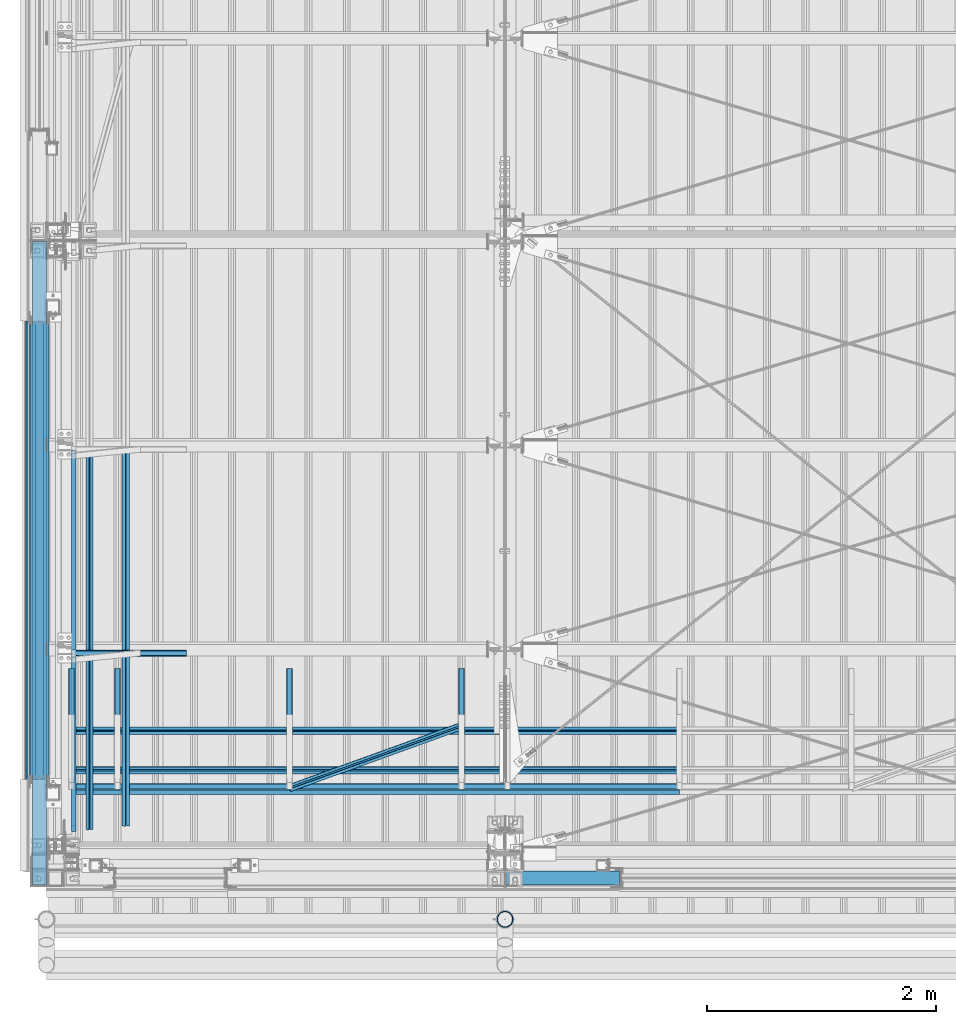
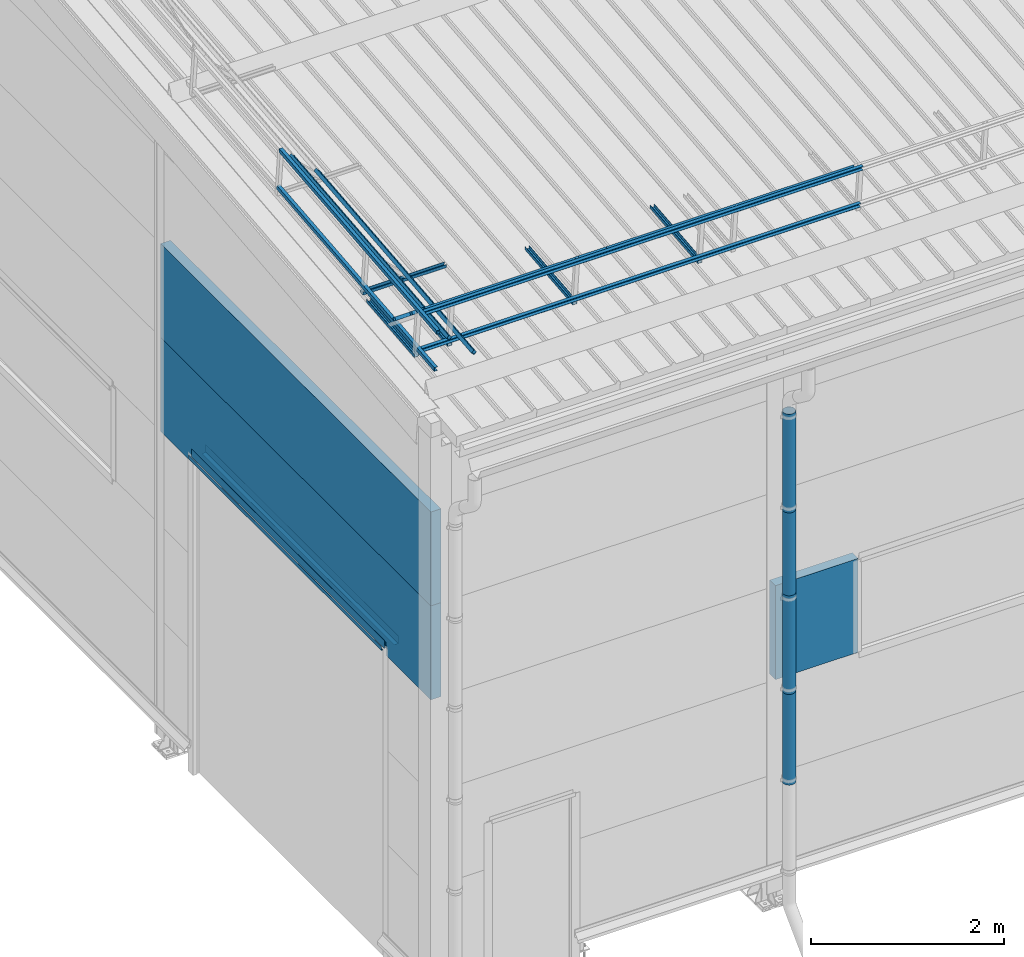
# One storey, part 29 of 709: 25 beams, 1 opening, 25 elements without a shape of their own.
"""IFC4 building model written with IfcOpenShell, lengths in millimetres."""

from ifc_helpers import new_model, si_unit, direction, frame, origin_with_axes, place, context, subcontext, project, spatial, line, indexed_curve, outline, extrude, material, element, aggregate, save


model = new_model("IFC4")

# Units and contexts
model_context = context("Model", 3, precision=0.2, world=origin_with_axes(), true_north=direction((0.0, 1.0)))
body_context = subcontext(model_context, "Body", "Model", "MODEL_VIEW")
ifc_project = project(units=[si_unit("LENGTHUNIT", "METRE", prefix="MILLI"), si_unit("AREAUNIT", "SQUARE_METRE"), si_unit("VOLUMEUNIT", "CUBIC_METRE"), si_unit("MASSUNIT", "GRAM", prefix="KILO"), si_unit("TIMEUNIT", "SECOND"), si_unit("PLANEANGLEUNIT", "RADIAN"), si_unit("SOLIDANGLEUNIT", "STERADIAN"), si_unit("THERMODYNAMICTEMPERATUREUNIT", "DEGREE_CELSIUS"), si_unit("LUMINOUSINTENSITYUNIT", "LUMEN")], contexts=[model_context])

# Site, building, storey
site_placement = place(None, origin_with_axes())
site = spatial("IfcSite", under=ifc_project, at=site_placement, CompositionType="ELEMENT")
building_placement = place(site_placement, origin_with_axes())
building = spatial("IfcBuilding", under=site, at=building_placement, Name="Undefined", CompositionType="ELEMENT")
storey_placement = place(building_placement, origin_with_axes())
storey = spatial("IfcBuildingStorey", under=building, at=storey_placement, Name="Undefined", CompositionType="ELEMENT", Elevation=0.0)

# Assembly, beam
assembly_1_placement = place(storey_placement, frame((220.0, 768.92298, 7577.16191), z_axis=(0.0, -0.099503719, 0.9950371902), x_axis=(0.0, 0.9950371902, 0.099503719)))
assembly_1 = element("IfcElementAssembly", 1, at=assembly_1_placement, inside=storey)
ifc_material_1 = material(Name="Steel_Undefined", Category="STEEL")
beam_1_placement = place(assembly_1_placement, origin_with_axes())
beam_1 = element("IfcBeam", 2, at=beam_1_placement, material=ifc_material_1, ObjectType="601", context=body_context, shape_type="SolidModel", body=[
    extrude(outline(indexed_curve([(-20.0, -25.0), (20.0, -25.0), (20.0, -22.5), (-17.5, -22.5), (-17.5, 22.5), (20.0, 22.5), (20.0, 25.0), (-20.0, 25.0)], segments=[line(1, 2, 3, 4, 5, 6, 7, 8, 1)])), frame((0.0, 0.0, 0.0), z_axis=(-1.0, 0.0, 0.0), x_axis=(0.0, 0.0, 1.0)), (0.0, 0.0, -1.0), 1000.0),
])
aggregate(assembly_1, [beam_1])

assembly_2_placement = place(storey_placement, frame((620.0, 768.92298, 7577.16191), z_axis=(0.0, -0.099503719, 0.9950371902), x_axis=(0.0, 0.9950371902, 0.099503719)))
assembly_2 = element("IfcElementAssembly", 3, at=assembly_2_placement, inside=storey)
beam_2_placement = place(assembly_2_placement, origin_with_axes())
beam_2 = element("IfcBeam", 4, at=beam_2_placement, material=ifc_material_1, ObjectType="601", context=body_context, shape_type="SolidModel", body=[
    extrude(outline(indexed_curve([(-20.0, -25.0), (20.0, -25.0), (20.0, -22.5), (-17.5, -22.5), (-17.5, 22.5), (20.0, 22.5), (20.0, 25.0), (-20.0, 25.0)], segments=[line(1, 2, 3, 4, 5, 6, 7, 8, 1)])), frame((0.0, 0.0, 0.0), z_axis=(-1.0, 0.0, 0.0), x_axis=(0.0, 0.0, 1.0)), (0.0, 0.0, -1.0), 1000.0),
])
aggregate(assembly_2, [beam_2])

assembly_3_placement = place(storey_placement, frame((2120.0, 768.92298, 7577.16191), z_axis=(0.0, -0.099503719, 0.9950371902), x_axis=(0.0, 0.9950371902, 0.099503719)))
assembly_3 = element("IfcElementAssembly", 5, at=assembly_3_placement, inside=storey)
beam_3_placement = place(assembly_3_placement, origin_with_axes())
beam_3 = element("IfcBeam", 6, at=beam_3_placement, material=ifc_material_1, ObjectType="601", context=body_context, shape_type="SolidModel", body=[
    extrude(outline(indexed_curve([(-20.0, -25.0), (20.0, -25.0), (20.0, -22.5), (-17.5, -22.5), (-17.5, 22.5), (20.0, 22.5), (20.0, 25.0), (-20.0, 25.0)], segments=[line(1, 2, 3, 4, 5, 6, 7, 8, 1)])), frame((0.0, 0.0, 0.0), z_axis=(-1.0, 0.0, 0.0), x_axis=(0.0, 0.0, 1.0)), (0.0, 0.0, -1.0), 1000.0),
])
aggregate(assembly_3, [beam_3])

assembly_4_placement = place(storey_placement, frame((3620.0, 768.92298, 7577.16191), z_axis=(0.0, -0.099503719, 0.9950371902), x_axis=(0.0, 0.9950371902, 0.099503719)))
assembly_4 = element("IfcElementAssembly", 7, at=assembly_4_placement, inside=storey)
beam_4_placement = place(assembly_4_placement, origin_with_axes())
beam_4 = element("IfcBeam", 8, at=beam_4_placement, material=ifc_material_1, ObjectType="601", context=body_context, shape_type="SolidModel", body=[
    extrude(outline(indexed_curve([(-20.0, -25.0), (20.0, -25.0), (20.0, -22.5), (-17.5, -22.5), (-17.5, 22.5), (20.0, 22.5), (20.0, 25.0), (-20.0, 25.0)], segments=[line(1, 2, 3, 4, 5, 6, 7, 8, 1)])), frame((0.0, 0.0, 0.0), z_axis=(-1.0, 0.0, 0.0), x_axis=(0.0, 0.0, 1.0)), (0.0, 0.0, -1.0), 1000.0),
])
aggregate(assembly_4, [beam_4])

assembly_5_placement = place(storey_placement, frame((220.0, 691.31008, 8152.29341), z_axis=(0.0, -0.9950371902, -0.099503719), x_axis=(1.0, 0.0, 0.0)))
assembly_5 = element("IfcElementAssembly", 9, at=assembly_5_placement, inside=storey)
beam_5_placement = place(assembly_5_placement, origin_with_axes())
beam_5 = element("IfcBeam", 10, at=beam_5_placement, material=ifc_material_1, ObjectType="604", context=body_context, shape_type="SolidModel", body=[
    extrude(outline(indexed_curve([(-20.0, -25.0), (20.0, -25.0), (20.0, -22.5), (-17.5, -22.5), (-17.5, 22.5), (20.0, 22.5), (20.0, 25.0), (-20.0, 25.0)], segments=[line(1, 2, 3, 4, 5, 6, 7, 8, 1)])), frame((0.0, 0.0, 0.0), z_axis=(-1.0, 0.0, 0.0), x_axis=(0.0, 0.0, 1.0)), (0.0, 0.0, -1.0), 5300.0),
])
aggregate(assembly_5, [beam_5])

assembly_6_placement = place(storey_placement, frame((220.0, 741.06194, 7654.77481), z_axis=(0.0, -0.9950371902, -0.099503719), x_axis=(1.0, 0.0, 0.0)))
assembly_6 = element("IfcElementAssembly", 11, at=assembly_6_placement, inside=storey)
beam_6_placement = place(assembly_6_placement, origin_with_axes())
beam_6 = element("IfcBeam", 12, at=beam_6_placement, material=ifc_material_1, ObjectType="604", context=body_context, shape_type="SolidModel", body=[
    extrude(outline(indexed_curve([(-20.0, -25.0), (20.0, -25.0), (20.0, -22.5), (-17.5, -22.5), (-17.5, 22.5), (20.0, 22.5), (20.0, 25.0), (-20.0, 25.0)], segments=[line(1, 2, 3, 4, 5, 6, 7, 8, 1)])), frame((0.0, 0.0, 0.0), z_axis=(-1.0, 0.0, 0.0), x_axis=(0.0, 0.0, 1.0)), (0.0, 0.0, -1.0), 5300.0),
])
aggregate(assembly_6, [beam_6])

assembly_7_placement = place(storey_placement, frame((220.0, 878.66704, 8043.11507), z_axis=(0.0, 0.6332377902, 0.7739572992), x_axis=(1.0, 0.0, 0.0)))
assembly_7 = element("IfcElementAssembly", 13, at=assembly_7_placement, inside=storey)
beam_7_placement = place(assembly_7_placement, origin_with_axes())
beam_7 = element("IfcBeam", 14, at=beam_7_placement, material=ifc_material_1, ObjectType="604", context=body_context, shape_type="SolidModel", body=[
    extrude(outline(indexed_curve([(-20.0, -25.0), (20.0, -25.0), (20.0, -22.5), (-17.5, -22.5), (-17.5, 22.5), (20.0, 22.5), (20.0, 25.0), (-20.0, 25.0)], segments=[line(1, 2, 3, 4, 5, 6, 7, 8, 1)])), frame((0.0, 0.0, 0.0), z_axis=(-1.0, 0.0, 0.0), x_axis=(0.0, 0.0, 1.0)), (0.0, 0.0, -1.0), 5300.0),
])
aggregate(assembly_7, [beam_7])

assembly_8_placement = place(storey_placement, frame((220.0, 1225.80867, 7759.0901), z_axis=(0.0, 0.6332377902, 0.7739572992), x_axis=(1.0, 0.0, 0.0)))
assembly_8 = element("IfcElementAssembly", 15, at=assembly_8_placement, inside=storey)
beam_8_placement = place(assembly_8_placement, origin_with_axes())
beam_8 = element("IfcBeam", 16, at=beam_8_placement, material=ifc_material_1, ObjectType="604", context=body_context, shape_type="SolidModel", body=[
    extrude(outline(indexed_curve([(-20.0, -25.0), (20.0, -25.0), (20.0, -22.5), (-17.5, -22.5), (-17.5, 22.5), (20.0, 22.5), (20.0, 25.0), (-20.0, 25.0)], segments=[line(1, 2, 3, 4, 5, 6, 7, 8, 1)])), frame((0.0, 0.0, 0.0), z_axis=(-1.0, 0.0, 0.0), x_axis=(0.0, 0.0, 1.0)), (0.0, 0.0, -1.0), 5300.0),
])
aggregate(assembly_8, [beam_8])

assembly_9_placement = place(storey_placement, frame((2120.0, 723.87558, 8169.76263), z_axis=(0.0, 0.6332377902, 0.7739572992), x_axis=(0.9061831398, 0.3272952929, -0.2677870579)))
assembly_9 = element("IfcElementAssembly", 17, at=assembly_9_placement, inside=storey)
beam_9_placement = place(assembly_9_placement, origin_with_axes())
beam_9 = element("IfcBeam", 18, at=beam_9_placement, material=ifc_material_1, ObjectType="605", context=body_context, shape_type="SolidModel", body=[
    extrude(outline(indexed_curve([(-20.0, -25.0), (20.0, -25.0), (20.0, -22.5), (-17.5, -22.5), (-17.5, 22.5), (20.0, 22.5), (20.0, 25.0), (-20.0, 25.0)], segments=[line(1, 2, 3, 4, 5, 6, 7, 8, 1)])), frame((0.0, 0.0, 0.0), z_axis=(-1.0, 0.0, 0.0), x_axis=(0.0, 0.0, 1.0)), (0.0, 0.0, -1.0), 1655.29454),
])
aggregate(assembly_9, [beam_9])

assembly_10_placement = place(storey_placement, frame((220.0, 1899.83375, 7690.25299), z_axis=(0.0, -0.099503719, 0.9950371902), x_axis=(1.0, 0.0, 0.0)))
assembly_10 = element("IfcElementAssembly", 19, at=assembly_10_placement, inside=storey)
beam_10_placement = place(assembly_10_placement, origin_with_axes())
beam_10 = element("IfcBeam", 20, at=beam_10_placement, material=ifc_material_1, ObjectType="601", context=body_context, shape_type="SolidModel", body=[
    extrude(outline(indexed_curve([(-20.0, -25.0), (20.0, -25.0), (20.0, -22.5), (-17.5, -22.5), (-17.5, 22.5), (20.0, 22.5), (20.0, 25.0), (-20.0, 25.0)], segments=[line(1, 2, 3, 4, 5, 6, 7, 8, 1)])), frame((0.0, 0.0, 0.0), z_axis=(-1.0, 0.0, 0.0), x_axis=(0.0, 0.0, 1.0)), (0.0, 0.0, -1.0), 1000.0),
])
aggregate(assembly_10, [beam_10])

assembly_11_placement = place(storey_placement, frame((240.0, 349.56581, 8118.11898), z_axis=(1.0, 0.0, 0.0), x_axis=(0.0, 0.9950371902, 0.099503719)))
assembly_11 = element("IfcElementAssembly", 21, at=assembly_11_placement, inside=storey)
beam_11_placement = place(assembly_11_placement, origin_with_axes())
beam_11 = element("IfcBeam", 22, at=beam_11_placement, material=ifc_material_1, ObjectType="608", context=body_context, shape_type="SolidModel", body=[
    extrude(outline(indexed_curve([(-20.0, -25.0), (20.0, -25.0), (20.0, -22.5), (-17.5, -22.5), (-17.5, 22.5), (20.0, 22.5), (20.0, 25.0), (-20.0, 25.0)], segments=[line(1, 2, 3, 4, 5, 6, 7, 8, 1)])), frame((0.0, 0.0, 0.0), z_axis=(-1.0, 0.0, 0.0), x_axis=(0.0, 0.0, 1.0)), (0.0, 0.0, -1.0), 3285.56115),
])
aggregate(assembly_11, [beam_11])

assembly_12_placement = place(storey_placement, frame((240.0, 399.31767, 7620.60038), z_axis=(1.0, 0.0, 0.0), x_axis=(0.0, 0.9950371902, 0.099503719)))
assembly_12 = element("IfcElementAssembly", 23, at=assembly_12_placement, inside=storey)
beam_12_placement = place(assembly_12_placement, origin_with_axes())
beam_12 = element("IfcBeam", 24, at=beam_12_placement, material=ifc_material_1, ObjectType="608", context=body_context, shape_type="SolidModel", body=[
    extrude(outline(indexed_curve([(-20.0, -25.0), (20.0, -25.0), (20.0, -22.5), (-17.5, -22.5), (-17.5, 22.5), (20.0, 22.5), (20.0, 25.0), (-20.0, 25.0)], segments=[line(1, 2, 3, 4, 5, 6, 7, 8, 1)])), frame((0.0, 0.0, 0.0), z_axis=(-1.0, 0.0, 0.0), x_axis=(0.0, 0.0, 1.0)), (0.0, 0.0, -1.0), 3285.56115),
])
aggregate(assembly_12, [beam_12])

assembly_13_placement = place(storey_placement, frame((375.56349, 362.23056, 7991.47142), z_axis=(0.7071067814, -0.0703597545, 0.7035975445), x_axis=(0.0, 0.9950371902, 0.099503719)))
assembly_13 = element("IfcElementAssembly", 25, at=assembly_13_placement, inside=storey)
beam_13_placement = place(assembly_13_placement, origin_with_axes())
beam_13 = element("IfcBeam", 26, at=beam_13_placement, material=ifc_material_1, ObjectType="608", context=body_context, shape_type="SolidModel", body=[
    extrude(outline(indexed_curve([(-20.0, -25.0), (20.0, -25.0), (20.0, -22.5), (-17.5, -22.5), (-17.5, 22.5), (20.0, 22.5), (20.0, 25.0), (-20.0, 25.0)], segments=[line(1, 2, 3, 4, 5, 6, 7, 8, 1)])), frame((0.0, 0.0, 0.0), z_axis=(-1.0, 0.0, 0.0), x_axis=(0.0, 0.0, 1.0)), (0.0, 0.0, -1.0), 3285.56115),
])
aggregate(assembly_13, [beam_13])

assembly_14_placement = place(storey_placement, frame((692.72078, 393.78889, 7675.88813), z_axis=(0.7071067814, -0.0703597545, 0.7035975445), x_axis=(0.0, 0.9950371902, 0.099503719)))
assembly_14 = element("IfcElementAssembly", 27, at=assembly_14_placement, inside=storey)
beam_14_placement = place(assembly_14_placement, origin_with_axes())
beam_14 = element("IfcBeam", 28, at=beam_14_placement, material=ifc_material_1, ObjectType="608", context=body_context, shape_type="SolidModel", body=[
    extrude(outline(indexed_curve([(-20.0, -25.0), (20.0, -25.0), (20.0, -22.5), (-17.5, -22.5), (-17.5, 22.5), (20.0, 22.5), (20.0, 25.0), (-20.0, 25.0)], segments=[line(1, 2, 3, 4, 5, 6, 7, 8, 1)])), frame((0.0, 0.0, 0.0), z_axis=(-1.0, 0.0, 0.0), x_axis=(0.0, 0.0, 1.0)), (0.0, 0.0, -1.0), 3285.56115),
])
aggregate(assembly_14, [beam_14])

assembly_15_placement = place(storey_placement, frame((4010.0, -60.0, 3275.0), z_axis=(0.0, 0.0, -1.0), x_axis=(1.0, 0.0, 0.0)))
assembly_15 = element("IfcElementAssembly", 29, at=assembly_15_placement, inside=storey)
ifc_material_2 = material(Name="Insulation", Category="Insulation")
beam_15_placement = place(assembly_15_placement, origin_with_axes())
beam_15 = element("IfcBeam", 30, at=beam_15_placement, material=ifc_material_2, ObjectType="P-110", context=body_context, shape_type="SolidModel", body=[
    extrude(outline(indexed_curve([(-595.0, -60.0), (595.0, -60.0), (595.0, 60.0), (-595.0, 60.0)], segments=[line(1, 2, 3, 4, 1)])), frame((0.0, 0.0, 0.0), z_axis=(-1.0, 0.0, 0.0), x_axis=(0.0, 0.0, 1.0)), (0.0, 0.0, -1.0), 990.0),
])
aggregate(assembly_15, [beam_15])

assembly_16_placement = place(storey_placement, frame((4000.0, -420.0, 6276.92297), z_axis=(0.0, 1.0, 0.0), x_axis=(0.0, 0.0, -1.0)))
assembly_16 = element("IfcElementAssembly", 31, at=assembly_16_placement, inside=storey)
beam_16_placement = place(assembly_16_placement, origin_with_axes())
beam_16 = element("IfcBeam", 32, at=beam_16_placement, material=ifc_material_1, ObjectType="614", context=body_context, shape_type="SolidModel", body=[
    extrude(outline(indexed_curve([(70.0, 0.0), (69.61653, 7.31699), (68.47033, 14.55382), (66.57396, 21.63119), (63.94818, 28.47157), (60.62178, 35.0), (56.63119, 41.14497), (52.02014, 46.83914), (46.83914, 52.02014), (41.14497, 56.63119), (35.0, 60.62178), (28.47157, 63.94818), (21.63119, 66.57396), (14.55382, 68.47033), (7.31699, 69.61653), (0.0, 70.0), (-7.31699, 69.61653), (-14.55382, 68.47033), (-21.63119, 66.57396), (-28.47157, 63.94818), (-35.0, 60.62178), (-41.14497, 56.63119), (-46.83914, 52.02014), (-52.02014, 46.83914), (-56.63119, 41.14497), (-60.62178, 35.0), (-63.94818, 28.47157), (-66.57396, 21.63119), (-68.47033, 14.55382), (-69.61653, 7.31699), (-70.0, 0.0), (-69.61653, -7.31699), (-68.47033, -14.55382), (-66.57396, -21.63119), (-63.94818, -28.47157), (-60.62178, -35.0), (-56.63119, -41.14497), (-52.02014, -46.83914), (-46.83914, -52.02014), (-41.14497, -56.63119), (-35.0, -60.62178), (-28.47157, -63.94818), (-21.63119, -66.57396), (-14.55382, -68.47033), (-7.31699, -69.61653), (0.0, -70.0), (7.31699, -69.61653), (14.55382, -68.47033), (21.63119, -66.57396), (28.47157, -63.94818), (35.0, -60.62178), (41.14497, -56.63119), (46.83914, -52.02014), (52.02014, -46.83914), (56.63119, -41.14497), (60.62178, -35.0), (63.94818, -28.47157), (66.57396, -21.63119), (68.47033, -14.55382), (69.61653, -7.31699)], segments=[line(1, 2, 3, 4, 5, 6, 7, 8, 9, 10, 11, 12, 13, 14, 15, 16, 17, 18, 19, 20, 21, 22, 23, 24, 25, 26, 27, 28, 29, 30, 31, 32, 33, 34, 35, 36, 37, 38, 39, 40, 41, 42, 43, 44, 45, 46, 47, 48, 49, 50, 51, 52, 53, 54, 55, 56, 57, 58, 59, 60, 1)]), holes=[indexed_curve([(65.0, 0.0), (64.64392, -6.79435), (63.57959, -13.51426), (61.81867, -20.0861), (59.38045, -26.43788), (56.29165, -32.5), (52.5861, -38.20604), (48.30441, -43.49349), (43.49349, -48.30441), (38.20604, -52.5861), (32.5, -56.29165), (26.43788, -59.38045), (20.0861, -61.81867), (13.51426, -63.57959), (6.79435, -64.64392), (0.0, -65.0), (-6.79435, -64.64392), (-13.51426, -63.57959), (-20.0861, -61.81867), (-26.43788, -59.38045), (-32.5, -56.29165), (-38.20604, -52.5861), (-43.49349, -48.30441), (-48.30441, -43.49349), (-52.5861, -38.20604), (-56.29165, -32.5), (-59.38045, -26.43788), (-61.81867, -20.0861), (-63.57959, -13.51426), (-64.64392, -6.79435), (-65.0, 0.0), (-64.64392, 6.79435), (-63.57959, 13.51426), (-61.81867, 20.0861), (-59.38045, 26.43788), (-56.29165, 32.5), (-52.5861, 38.20604), (-48.30441, 43.49349), (-43.49349, 48.30441), (-38.20604, 52.5861), (-32.5, 56.29165), (-26.43788, 59.38045), (-20.0861, 61.81867), (-13.51426, 63.57959), (-6.79435, 64.64392), (0.0, 65.0), (6.79435, 64.64392), (13.51426, 63.57959), (20.0861, 61.81867), (26.43788, 59.38045), (32.5, 56.29165), (38.20604, 52.5861), (43.49349, 48.30441), (48.30441, 43.49349), (52.5861, 38.20604), (56.29165, 32.5), (59.38045, 26.43788), (61.81867, 20.0861), (63.57959, 13.51426), (64.64392, 6.79435)], segments=[line(1, 2, 3, 4, 5, 6, 7, 8, 9, 10, 11, 12, 13, 14, 15, 16, 17, 18, 19, 20, 21, 22, 23, 24, 25, 26, 27, 28, 29, 30, 31, 32, 33, 34, 35, 36, 37, 38, 39, 40, 41, 42, 43, 44, 45, 46, 47, 48, 49, 50, 51, 52, 53, 54, 55, 56, 57, 58, 59, 60, 1)])]), frame((0.0, 0.0, 0.0), z_axis=(-1.0, 0.0, 0.0), x_axis=(0.0, 0.0, 1.0)), (0.0, 0.0, -1.0), 1250.0),
])
aggregate(assembly_16, [beam_16])

assembly_17_placement = place(storey_placement, frame((4000.0, -420.0, 5126.92297), z_axis=(0.0, 1.0, 0.0), x_axis=(0.0, 0.0, -1.0)))
assembly_17 = element("IfcElementAssembly", 33, at=assembly_17_placement, inside=storey)
beam_17_placement = place(assembly_17_placement, origin_with_axes())
beam_17 = element("IfcBeam", 34, at=beam_17_placement, material=ifc_material_1, ObjectType="614", context=body_context, shape_type="SolidModel", body=[
    extrude(outline(indexed_curve([(70.0, 0.0), (69.61653, 7.31699), (68.47033, 14.55382), (66.57396, 21.63119), (63.94818, 28.47157), (60.62178, 35.0), (56.63119, 41.14497), (52.02014, 46.83914), (46.83914, 52.02014), (41.14497, 56.63119), (35.0, 60.62178), (28.47157, 63.94818), (21.63119, 66.57396), (14.55382, 68.47033), (7.31699, 69.61653), (0.0, 70.0), (-7.31699, 69.61653), (-14.55382, 68.47033), (-21.63119, 66.57396), (-28.47157, 63.94818), (-35.0, 60.62178), (-41.14497, 56.63119), (-46.83914, 52.02014), (-52.02014, 46.83914), (-56.63119, 41.14497), (-60.62178, 35.0), (-63.94818, 28.47157), (-66.57396, 21.63119), (-68.47033, 14.55382), (-69.61653, 7.31699), (-70.0, 0.0), (-69.61653, -7.31699), (-68.47033, -14.55382), (-66.57396, -21.63119), (-63.94818, -28.47157), (-60.62178, -35.0), (-56.63119, -41.14497), (-52.02014, -46.83914), (-46.83914, -52.02014), (-41.14497, -56.63119), (-35.0, -60.62178), (-28.47157, -63.94818), (-21.63119, -66.57396), (-14.55382, -68.47033), (-7.31699, -69.61653), (0.0, -70.0), (7.31699, -69.61653), (14.55382, -68.47033), (21.63119, -66.57396), (28.47157, -63.94818), (35.0, -60.62178), (41.14497, -56.63119), (46.83914, -52.02014), (52.02014, -46.83914), (56.63119, -41.14497), (60.62178, -35.0), (63.94818, -28.47157), (66.57396, -21.63119), (68.47033, -14.55382), (69.61653, -7.31699)], segments=[line(1, 2, 3, 4, 5, 6, 7, 8, 9, 10, 11, 12, 13, 14, 15, 16, 17, 18, 19, 20, 21, 22, 23, 24, 25, 26, 27, 28, 29, 30, 31, 32, 33, 34, 35, 36, 37, 38, 39, 40, 41, 42, 43, 44, 45, 46, 47, 48, 49, 50, 51, 52, 53, 54, 55, 56, 57, 58, 59, 60, 1)]), holes=[indexed_curve([(65.0, 0.0), (64.64392, -6.79435), (63.57959, -13.51426), (61.81867, -20.0861), (59.38045, -26.43788), (56.29165, -32.5), (52.5861, -38.20604), (48.30441, -43.49349), (43.49349, -48.30441), (38.20604, -52.5861), (32.5, -56.29165), (26.43788, -59.38045), (20.0861, -61.81867), (13.51426, -63.57959), (6.79435, -64.64392), (0.0, -65.0), (-6.79435, -64.64392), (-13.51426, -63.57959), (-20.0861, -61.81867), (-26.43788, -59.38045), (-32.5, -56.29165), (-38.20604, -52.5861), (-43.49349, -48.30441), (-48.30441, -43.49349), (-52.5861, -38.20604), (-56.29165, -32.5), (-59.38045, -26.43788), (-61.81867, -20.0861), (-63.57959, -13.51426), (-64.64392, -6.79435), (-65.0, 0.0), (-64.64392, 6.79435), (-63.57959, 13.51426), (-61.81867, 20.0861), (-59.38045, 26.43788), (-56.29165, 32.5), (-52.5861, 38.20604), (-48.30441, 43.49349), (-43.49349, 48.30441), (-38.20604, 52.5861), (-32.5, 56.29165), (-26.43788, 59.38045), (-20.0861, 61.81867), (-13.51426, 63.57959), (-6.79435, 64.64392), (0.0, 65.0), (6.79435, 64.64392), (13.51426, 63.57959), (20.0861, 61.81867), (26.43788, 59.38045), (32.5, 56.29165), (38.20604, 52.5861), (43.49349, 48.30441), (48.30441, 43.49349), (52.5861, 38.20604), (56.29165, 32.5), (59.38045, 26.43788), (61.81867, 20.0861), (63.57959, 13.51426), (64.64392, 6.79435)], segments=[line(1, 2, 3, 4, 5, 6, 7, 8, 9, 10, 11, 12, 13, 14, 15, 16, 17, 18, 19, 20, 21, 22, 23, 24, 25, 26, 27, 28, 29, 30, 31, 32, 33, 34, 35, 36, 37, 38, 39, 40, 41, 42, 43, 44, 45, 46, 47, 48, 49, 50, 51, 52, 53, 54, 55, 56, 57, 58, 59, 60, 1)])]), frame((0.0, 0.0, 0.0), z_axis=(-1.0, 0.0, 0.0), x_axis=(0.0, 0.0, 1.0)), (0.0, 0.0, -1.0), 1250.0),
])
aggregate(assembly_17, [beam_17])

assembly_18_placement = place(storey_placement, frame((4000.0, -420.0, 3976.92297), z_axis=(0.0, 1.0, 0.0), x_axis=(0.0, 0.0, -1.0)))
assembly_18 = element("IfcElementAssembly", 35, at=assembly_18_placement, inside=storey)
beam_18_placement = place(assembly_18_placement, origin_with_axes())
beam_18 = element("IfcBeam", 36, at=beam_18_placement, material=ifc_material_1, ObjectType="614", context=body_context, shape_type="SolidModel", body=[
    extrude(outline(indexed_curve([(70.0, 0.0), (69.61653, 7.31699), (68.47033, 14.55382), (66.57396, 21.63119), (63.94818, 28.47157), (60.62178, 35.0), (56.63119, 41.14497), (52.02014, 46.83914), (46.83914, 52.02014), (41.14497, 56.63119), (35.0, 60.62178), (28.47157, 63.94818), (21.63119, 66.57396), (14.55382, 68.47033), (7.31699, 69.61653), (0.0, 70.0), (-7.31699, 69.61653), (-14.55382, 68.47033), (-21.63119, 66.57396), (-28.47157, 63.94818), (-35.0, 60.62178), (-41.14497, 56.63119), (-46.83914, 52.02014), (-52.02014, 46.83914), (-56.63119, 41.14497), (-60.62178, 35.0), (-63.94818, 28.47157), (-66.57396, 21.63119), (-68.47033, 14.55382), (-69.61653, 7.31699), (-70.0, 0.0), (-69.61653, -7.31699), (-68.47033, -14.55382), (-66.57396, -21.63119), (-63.94818, -28.47157), (-60.62178, -35.0), (-56.63119, -41.14497), (-52.02014, -46.83914), (-46.83914, -52.02014), (-41.14497, -56.63119), (-35.0, -60.62178), (-28.47157, -63.94818), (-21.63119, -66.57396), (-14.55382, -68.47033), (-7.31699, -69.61653), (0.0, -70.0), (7.31699, -69.61653), (14.55382, -68.47033), (21.63119, -66.57396), (28.47157, -63.94818), (35.0, -60.62178), (41.14497, -56.63119), (46.83914, -52.02014), (52.02014, -46.83914), (56.63119, -41.14497), (60.62178, -35.0), (63.94818, -28.47157), (66.57396, -21.63119), (68.47033, -14.55382), (69.61653, -7.31699)], segments=[line(1, 2, 3, 4, 5, 6, 7, 8, 9, 10, 11, 12, 13, 14, 15, 16, 17, 18, 19, 20, 21, 22, 23, 24, 25, 26, 27, 28, 29, 30, 31, 32, 33, 34, 35, 36, 37, 38, 39, 40, 41, 42, 43, 44, 45, 46, 47, 48, 49, 50, 51, 52, 53, 54, 55, 56, 57, 58, 59, 60, 1)]), holes=[indexed_curve([(65.0, 0.0), (64.64392, -6.79435), (63.57959, -13.51426), (61.81867, -20.0861), (59.38045, -26.43788), (56.29165, -32.5), (52.5861, -38.20604), (48.30441, -43.49349), (43.49349, -48.30441), (38.20604, -52.5861), (32.5, -56.29165), (26.43788, -59.38045), (20.0861, -61.81867), (13.51426, -63.57959), (6.79435, -64.64392), (0.0, -65.0), (-6.79435, -64.64392), (-13.51426, -63.57959), (-20.0861, -61.81867), (-26.43788, -59.38045), (-32.5, -56.29165), (-38.20604, -52.5861), (-43.49349, -48.30441), (-48.30441, -43.49349), (-52.5861, -38.20604), (-56.29165, -32.5), (-59.38045, -26.43788), (-61.81867, -20.0861), (-63.57959, -13.51426), (-64.64392, -6.79435), (-65.0, 0.0), (-64.64392, 6.79435), (-63.57959, 13.51426), (-61.81867, 20.0861), (-59.38045, 26.43788), (-56.29165, 32.5), (-52.5861, 38.20604), (-48.30441, 43.49349), (-43.49349, 48.30441), (-38.20604, 52.5861), (-32.5, 56.29165), (-26.43788, 59.38045), (-20.0861, 61.81867), (-13.51426, 63.57959), (-6.79435, 64.64392), (0.0, 65.0), (6.79435, 64.64392), (13.51426, 63.57959), (20.0861, 61.81867), (26.43788, 59.38045), (32.5, 56.29165), (38.20604, 52.5861), (43.49349, 48.30441), (48.30441, 43.49349), (52.5861, 38.20604), (56.29165, 32.5), (59.38045, 26.43788), (61.81867, 20.0861), (63.57959, 13.51426), (64.64392, 6.79435)], segments=[line(1, 2, 3, 4, 5, 6, 7, 8, 9, 10, 11, 12, 13, 14, 15, 16, 17, 18, 19, 20, 21, 22, 23, 24, 25, 26, 27, 28, 29, 30, 31, 32, 33, 34, 35, 36, 37, 38, 39, 40, 41, 42, 43, 44, 45, 46, 47, 48, 49, 50, 51, 52, 53, 54, 55, 56, 57, 58, 59, 60, 1)])]), frame((0.0, 0.0, 0.0), z_axis=(-1.0, 0.0, 0.0), x_axis=(0.0, 0.0, 1.0)), (0.0, 0.0, -1.0), 1250.0),
])
aggregate(assembly_18, [beam_18])

assembly_19_placement = place(storey_placement, frame((4000.0, -420.0, 2826.92297), z_axis=(0.0, 1.0, 0.0), x_axis=(0.0, 0.0, -1.0)))
assembly_19 = element("IfcElementAssembly", 37, at=assembly_19_placement, inside=storey)
beam_19_placement = place(assembly_19_placement, origin_with_axes())
beam_19 = element("IfcBeam", 38, at=beam_19_placement, material=ifc_material_1, ObjectType="614", context=body_context, shape_type="SolidModel", body=[
    extrude(outline(indexed_curve([(70.0, 0.0), (69.61653, 7.31699), (68.47033, 14.55382), (66.57396, 21.63119), (63.94818, 28.47157), (60.62178, 35.0), (56.63119, 41.14497), (52.02014, 46.83914), (46.83914, 52.02014), (41.14497, 56.63119), (35.0, 60.62178), (28.47157, 63.94818), (21.63119, 66.57396), (14.55382, 68.47033), (7.31699, 69.61653), (0.0, 70.0), (-7.31699, 69.61653), (-14.55382, 68.47033), (-21.63119, 66.57396), (-28.47157, 63.94818), (-35.0, 60.62178), (-41.14497, 56.63119), (-46.83914, 52.02014), (-52.02014, 46.83914), (-56.63119, 41.14497), (-60.62178, 35.0), (-63.94818, 28.47157), (-66.57396, 21.63119), (-68.47033, 14.55382), (-69.61653, 7.31699), (-70.0, 0.0), (-69.61653, -7.31699), (-68.47033, -14.55382), (-66.57396, -21.63119), (-63.94818, -28.47157), (-60.62178, -35.0), (-56.63119, -41.14497), (-52.02014, -46.83914), (-46.83914, -52.02014), (-41.14497, -56.63119), (-35.0, -60.62178), (-28.47157, -63.94818), (-21.63119, -66.57396), (-14.55382, -68.47033), (-7.31699, -69.61653), (0.0, -70.0), (7.31699, -69.61653), (14.55382, -68.47033), (21.63119, -66.57396), (28.47157, -63.94818), (35.0, -60.62178), (41.14497, -56.63119), (46.83914, -52.02014), (52.02014, -46.83914), (56.63119, -41.14497), (60.62178, -35.0), (63.94818, -28.47157), (66.57396, -21.63119), (68.47033, -14.55382), (69.61653, -7.31699)], segments=[line(1, 2, 3, 4, 5, 6, 7, 8, 9, 10, 11, 12, 13, 14, 15, 16, 17, 18, 19, 20, 21, 22, 23, 24, 25, 26, 27, 28, 29, 30, 31, 32, 33, 34, 35, 36, 37, 38, 39, 40, 41, 42, 43, 44, 45, 46, 47, 48, 49, 50, 51, 52, 53, 54, 55, 56, 57, 58, 59, 60, 1)]), holes=[indexed_curve([(65.0, 0.0), (64.64392, -6.79435), (63.57959, -13.51426), (61.81867, -20.0861), (59.38045, -26.43788), (56.29165, -32.5), (52.5861, -38.20604), (48.30441, -43.49349), (43.49349, -48.30441), (38.20604, -52.5861), (32.5, -56.29165), (26.43788, -59.38045), (20.0861, -61.81867), (13.51426, -63.57959), (6.79435, -64.64392), (0.0, -65.0), (-6.79435, -64.64392), (-13.51426, -63.57959), (-20.0861, -61.81867), (-26.43788, -59.38045), (-32.5, -56.29165), (-38.20604, -52.5861), (-43.49349, -48.30441), (-48.30441, -43.49349), (-52.5861, -38.20604), (-56.29165, -32.5), (-59.38045, -26.43788), (-61.81867, -20.0861), (-63.57959, -13.51426), (-64.64392, -6.79435), (-65.0, 0.0), (-64.64392, 6.79435), (-63.57959, 13.51426), (-61.81867, 20.0861), (-59.38045, 26.43788), (-56.29165, 32.5), (-52.5861, 38.20604), (-48.30441, 43.49349), (-43.49349, 48.30441), (-38.20604, 52.5861), (-32.5, 56.29165), (-26.43788, 59.38045), (-20.0861, 61.81867), (-13.51426, 63.57959), (-6.79435, 64.64392), (0.0, 65.0), (6.79435, 64.64392), (13.51426, 63.57959), (20.0861, 61.81867), (26.43788, 59.38045), (32.5, 56.29165), (38.20604, 52.5861), (43.49349, 48.30441), (48.30441, 43.49349), (52.5861, 38.20604), (56.29165, 32.5), (59.38045, 26.43788), (61.81867, 20.0861), (63.57959, 13.51426), (64.64392, 6.79435)], segments=[line(1, 2, 3, 4, 5, 6, 7, 8, 9, 10, 11, 12, 13, 14, 15, 16, 17, 18, 19, 20, 21, 22, 23, 24, 25, 26, 27, 28, 29, 30, 31, 32, 33, 34, 35, 36, 37, 38, 39, 40, 41, 42, 43, 44, 45, 46, 47, 48, 49, 50, 51, 52, 53, 54, 55, 56, 57, 58, 59, 60, 1)])]), frame((0.0, 0.0, 0.0), z_axis=(-1.0, 0.0, 0.0), x_axis=(0.0, 0.0, 1.0)), (0.0, 0.0, -1.0), 1250.0),
])
aggregate(assembly_19, [beam_19])

# Assembly, beam, voiding feature
assembly_20_placement = place(storey_placement, frame((-60.0, -120.0, 4465.0), z_axis=(0.0, 0.0, -1.0), x_axis=(0.0, 1.0, 0.0)))
assembly_20 = element("IfcElementAssembly", 39, at=assembly_20_placement, inside=storey)
beam_20_placement = place(assembly_20_placement, origin_with_axes())
beam_20 = element("IfcBeam", 40, at=beam_20_placement, material=ifc_material_2, ObjectType="P-129", context=body_context, shape_type="SolidModel", body=[
    extrude(outline(indexed_curve([(-595.0, -60.0), (595.0, -60.0), (595.0, 60.0), (-595.0, 60.0)], segments=[line(1, 2, 3, 4, 1)])), frame((0.0, 0.0, 0.0), z_axis=(-1.0, 0.0, 0.0), x_axis=(0.0, 0.0, 1.0)), (0.0, 0.0, -1.0), 5610.0),
])
voiding_feature_placement = place(beam_20_placement, frame((920.0, 0.0, 465.0), z_axis=(0.0, 1.0, 0.0), x_axis=(0.0, 0.0, 1.0)))
element("IfcVoidingFeature", 41, at=voiding_feature_placement, cuts=beam_20, Name="opening", PredefinedType="HOLE", context=body_context, shape_type="SolidModel", body=[
    extrude(outline(indexed_curve([(0.0, 0.0), (4050.0, 0.0), (4050.0, 4000.0), (0.0, 4000.0)], segments=[line(1, 2, 3, 4, 1)])), frame((0.0, 0.0, 62.5), z_axis=(0.0, 0.0, 1.0), x_axis=(1.0, 0.0, 0.0)), (0.0, 0.0, -1.0), 125.0),
])
aggregate(assembly_20, [beam_20])

# Assembly, beam
assembly_21_placement = place(storey_placement, frame((-60.0, -120.0, 5655.0), z_axis=(0.0, 0.0, -1.0), x_axis=(0.0, 1.0, 0.0)))
assembly_21 = element("IfcElementAssembly", 42, at=assembly_21_placement, inside=storey)
beam_21_placement = place(assembly_21_placement, origin_with_axes())
beam_21 = element("IfcBeam", 43, at=beam_21_placement, material=ifc_material_2, ObjectType="P-130", context=body_context, shape_type="SolidModel", body=[
    extrude(outline(indexed_curve([(-595.0, -60.0), (595.0, -60.0), (595.0, 60.0), (-595.0, 60.0)], segments=[line(1, 2, 3, 4, 1)])), frame((0.0, 0.0, 0.0), z_axis=(-1.0, 0.0, 0.0), x_axis=(0.0, 0.0, 1.0)), (0.0, 0.0, -1.0), 5610.0),
])
aggregate(assembly_21, [beam_21])

assembly_22_placement = place(storey_placement, frame((-1.0, 800.0, 3975.0), z_axis=(1.0, 0.0, 0.0), x_axis=(0.0, 1.0, 0.0)))
assembly_22 = element("IfcElementAssembly", 44, at=assembly_22_placement, inside=storey)
beam_22_placement = place(assembly_22_placement, origin_with_axes())
beam_22 = element("IfcBeam", 45, at=beam_22_placement, material=ifc_material_1, context=body_context, shape_type="SolidModel", body=[
    extrude(outline(indexed_curve([(-25.0, -1.0), (25.0, -1.0), (25.0, 99.0), (23.0, 99.0), (23.0, 1.0), (-25.0, 1.0)], segments=[line(1, 2, 3, 4, 5, 6, 1)])), frame((0.0, 0.0, 0.0), z_axis=(-1.0, 0.0, 0.0), x_axis=(0.0, 0.0, 1.0)), (0.0, 0.0, -1.0), 4000.0),
])
aggregate(assembly_22, [beam_22])

assembly_23_placement = place(storey_placement, frame((-121.0, 4800.0, 3975.0), z_axis=(-1.0, 0.0, 0.0), x_axis=(0.0, -1.0, 0.0)))
assembly_23 = element("IfcElementAssembly", 46, at=assembly_23_placement, inside=storey)
beam_23_placement = place(assembly_23_placement, origin_with_axes())
beam_23 = element("IfcBeam", 47, at=beam_23_placement, material=ifc_material_1, context=body_context, shape_type="SolidModel", body=[
    extrude(outline(indexed_curve([(-25.0, -1.0), (25.0, -1.0), (25.0, 99.0), (23.0, 99.0), (23.0, 1.0), (-25.0, 1.0)], segments=[line(1, 2, 3, 4, 5, 6, 1)])), frame((0.0, 0.0, 0.0), z_axis=(-1.0, 0.0, 0.0), x_axis=(0.0, 0.0, 1.0)), (0.0, 0.0, -1.0), 4000.0),
])
aggregate(assembly_23, [beam_23])

assembly_24_placement = place(storey_placement, frame((-60.0, 4800.0, 4020.0), z_axis=(1.0, 0.0, 0.0), x_axis=(0.0, -1.0, 0.0)))
assembly_24 = element("IfcElementAssembly", 48, at=assembly_24_placement, inside=storey)
beam_24_placement = place(assembly_24_placement, origin_with_axes())
beam_24 = element("IfcBeam", 49, at=beam_24_placement, material=ifc_material_1, context=body_context, shape_type="SolidModel", body=[
    extrude(outline(indexed_curve([(-70.0, -25.0), (-68.0, -25.0), (-68.0, 23.0), (68.0, 23.0), (68.0, -25.0), (70.0, -25.0), (70.0, 25.0), (-70.0, 25.0)], segments=[line(1, 2, 3, 4, 5, 6, 7, 8, 1)])), frame((0.0, 0.0, 0.0), z_axis=(-1.0, 0.0, 0.0), x_axis=(0.0, 0.0, 1.0)), (0.0, 0.0, -1.0), 4000.0),
])
aggregate(assembly_24, [beam_24])

assembly_25_placement = place(storey_placement, frame((-171.0, 4800.0, 3960.0), z_axis=(-1.0, 0.0, 0.0), x_axis=(0.0, -1.0, 0.0)))
assembly_25 = element("IfcElementAssembly", 50, at=assembly_25_placement, inside=storey)
beam_25_placement = place(assembly_25_placement, origin_with_axes())
beam_25 = element("IfcBeam", 51, at=beam_25_placement, material=ifc_material_1, context=body_context, shape_type="SolidModel", body=[
    extrude(outline(indexed_curve([(-10.0, -1.0), (10.0, -1.0), (10.0, 49.0), (8.0, 49.0), (8.0, 1.0), (-10.0, 1.0)], segments=[line(1, 2, 3, 4, 5, 6, 1)])), frame((0.0, 0.0, 0.0), z_axis=(-1.0, 0.0, 0.0), x_axis=(0.0, 0.0, 1.0)), (0.0, 0.0, -1.0), 4000.0),
])
aggregate(assembly_25, [beam_25])

save(model, "model.ifc")
